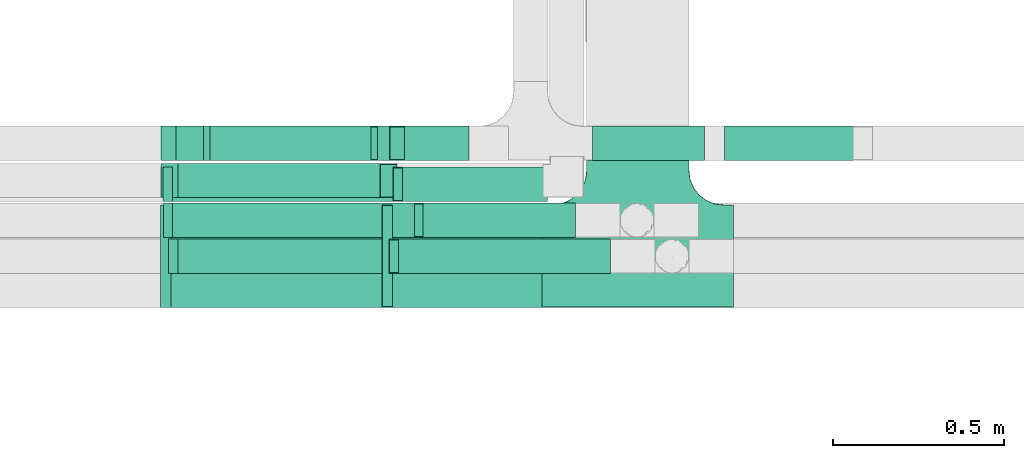
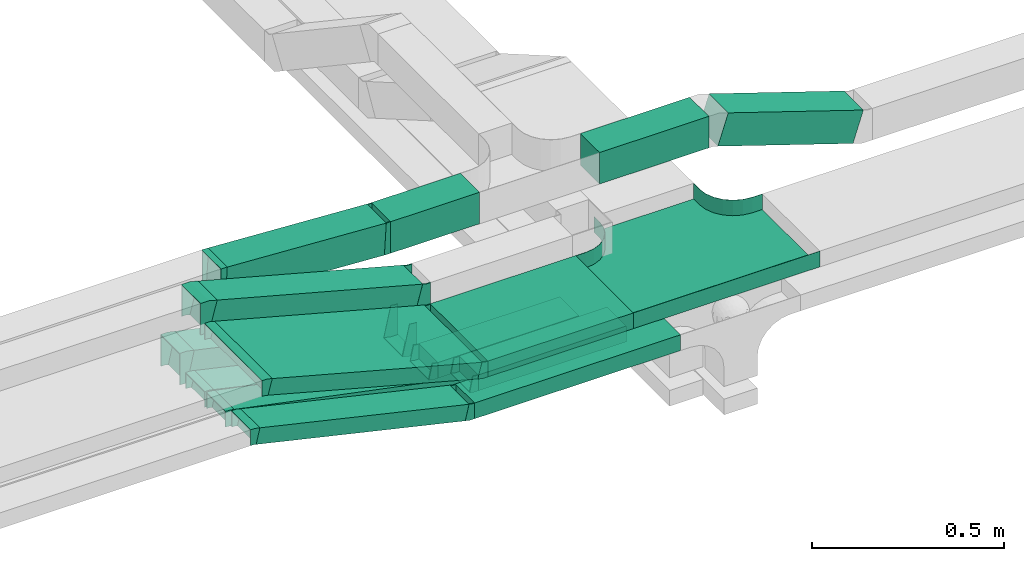
# One storey, part 10 of 14: 15 flow fittings, 14 flow segments.
"""IFC2X3 building model written with IfcOpenShell, lengths in millimetres."""

from ifc_helpers import new_model, entity, si_unit, converted_unit, derived_unit, direction, frame, frame_2d, origin, origin_2d_with_axis, place, context, subcontext, project, spatial, rectangle, extrude, faceted_brep, source, transform, mapped, material, type_object, type_shapes, element, save


model = new_model("IFC2X3")

# Units and contexts
model_context = context("Model", 3, precision=0.01, world=origin(), true_north=direction((6.12303176911189e-17, 1.0)))
body_context = subcontext(model_context, "Body", "Model", "MODEL_VIEW")
ifc_project = project(units=[si_unit("LENGTHUNIT", "METRE", prefix="MILLI"), si_unit("AREAUNIT", "SQUARE_METRE"), si_unit("VOLUMEUNIT", "CUBIC_METRE"), converted_unit("PLANEANGLEUNIT", "DEGREE", entity("IfcRatioMeasure", 0.0174532925199433), si_unit("PLANEANGLEUNIT", "RADIAN"), dimensions=[0, 0, 0, 0, 0, 0, 0]), si_unit("MASSUNIT", "GRAM", prefix="KILO"), derived_unit("MASSDENSITYUNIT", [(si_unit("MASSUNIT", "GRAM", prefix="KILO"), 1), (si_unit("LENGTHUNIT", "METRE"), -3)]), derived_unit("MOMENTOFINERTIAUNIT", [(si_unit("LENGTHUNIT", "METRE"), 4)]), si_unit("TIMEUNIT", "SECOND"), si_unit("FREQUENCYUNIT", "HERTZ"), si_unit("THERMODYNAMICTEMPERATUREUNIT", "DEGREE_CELSIUS"), derived_unit("THERMALTRANSMITTANCEUNIT", [(si_unit("MASSUNIT", "GRAM", prefix="KILO"), 1), (si_unit("THERMODYNAMICTEMPERATUREUNIT", "KELVIN"), -1), (si_unit("TIMEUNIT", "SECOND"), -3)]), derived_unit("VOLUMETRICFLOWRATEUNIT", [(si_unit("LENGTHUNIT", "METRE"), 3), (si_unit("TIMEUNIT", "SECOND"), -1)]), derived_unit("MASSFLOWRATEUNIT", [(si_unit("MASSUNIT", "GRAM", prefix="KILO"), 1), (si_unit("TIMEUNIT", "SECOND"), -1)]), derived_unit("ROTATIONALFREQUENCYUNIT", [(si_unit("TIMEUNIT", "SECOND"), -1)]), si_unit("ELECTRICCURRENTUNIT", "AMPERE"), si_unit("ELECTRICVOLTAGEUNIT", "VOLT"), si_unit("POWERUNIT", "WATT"), si_unit("FORCEUNIT", "NEWTON", prefix="KILO"), si_unit("ILLUMINANCEUNIT", "LUX"), si_unit("LUMINOUSFLUXUNIT", "LUMEN"), si_unit("LUMINOUSINTENSITYUNIT", "CANDELA"), derived_unit("USERDEFINED", [(si_unit("MASSUNIT", "GRAM", prefix="KILO"), -1), (si_unit("LENGTHUNIT", "METRE"), -2), (si_unit("TIMEUNIT", "SECOND"), 3), (si_unit("LUMINOUSFLUXUNIT", "LUMEN"), 1)]), derived_unit("LINEARVELOCITYUNIT", [(si_unit("LENGTHUNIT", "METRE"), 1), (si_unit("TIMEUNIT", "SECOND"), -1)]), si_unit("PRESSUREUNIT", "PASCAL"), derived_unit("USERDEFINED", [(si_unit("LENGTHUNIT", "METRE"), -2), (si_unit("MASSUNIT", "GRAM", prefix="KILO"), 1), (si_unit("TIMEUNIT", "SECOND"), -2)]), derived_unit("LINEARFORCEUNIT", [(si_unit("MASSUNIT", "GRAM", prefix="KILO"), 1), (si_unit("LENGTHUNIT", "METRE"), 1), (si_unit("TIMEUNIT", "SECOND"), -2), (si_unit("LENGTHUNIT", "METRE"), -1)]), derived_unit("PLANARFORCEUNIT", [(si_unit("MASSUNIT", "GRAM", prefix="KILO"), 1), (si_unit("LENGTHUNIT", "METRE"), 1), (si_unit("TIMEUNIT", "SECOND"), -2), (si_unit("LENGTHUNIT", "METRE"), -2)])], contexts=[model_context])

# Site, building, storey
site_placement = place(None, origin())
site = spatial("IfcSite", under=ifc_project, at=site_placement, CompositionType="ELEMENT")
building_placement = place(site_placement, origin())
building = spatial("IfcBuilding", under=site, at=building_placement, CompositionType="ELEMENT")
storey_placement = place(building_placement, frame((0.0, 0.0, 19800.0)))
storey = spatial("IfcBuildingStorey", under=building, at=storey_placement, CompositionType="ELEMENT", Elevation=19800.0)

# Flow segments
cable_carrier_segment_type = type_object("IfcCableCarrierSegmentType", PredefinedType="CABLETRAYSEGMENT")
flow_segment_1_placement = place(storey_placement, frame((63916.07, 9720.0, 2800.0)))
element("IfcFlowSegment", 1, at=flow_segment_1_placement, inside=storey, type_object=cable_carrier_segment_type, context=body_context, shape_type="SweptSolid", body=[
    extrude(rectangle(XDim=444.461560115162, YDim=99.9999999999989, at=origin_2d_with_axis()), frame((222.23, 50.0, 0.0), z_axis=(0.0, 0.0, 1.0), x_axis=(-1.0, 0.0, 0.0)), (0.0, 0.0, 1.0), 49.9999999999973),
])
flow_segment_2_placement = place(storey_placement, frame((63844.36, 9615.0, 2800.0)))
element("IfcFlowSegment", 2, at=flow_segment_2_placement, inside=storey, type_object=cable_carrier_segment_type, context=body_context, shape_type="SweptSolid", body=[
    extrude(rectangle(XDim=618.676195552314, YDim=100.000000000001, at=origin_2d_with_axis()), frame((309.34, 50.0, 0.0), z_axis=(0.0, 0.0, 1.0), x_axis=(-1.0, 0.0, 0.0)), (0.0, 0.0, 1.0), 49.9999999999973),
])
flow_segment_3_placement = place(storey_placement, frame((64765.17, 9945.0, 3009.28)))
element("IfcFlowSegment", 3, at=flow_segment_3_placement, inside=storey, type_object=cable_carrier_segment_type, context=body_context, shape_type="SweptSolid", body=[
    extrude(rectangle(XDim=99.9999999999972, YDim=99.9999999999989, at=origin_2d_with_axis()), frame((15.59, 50.0, 180.61), z_axis=(0.950175096611784, 0.0, -0.311716675490399), x_axis=(0.311716675490399, 0.0, 0.950175096611784)), (0.0, 0.0, 1.0), 426.997112921798),
])
flow_segment_4_placement = place(storey_placement, frame((64410.06, 9945.0, 3146.68)))
element("IfcFlowSegment", 4, at=flow_segment_4_placement, inside=storey, type_object=cable_carrier_segment_type, context=body_context, shape_type="SweptSolid", body=[
    extrude(rectangle(XDim=328.216762954596, YDim=99.9999999999989, at=origin_2d_with_axis()), frame((164.11, 50.0, 0.0)), (0.0, 0.0, 1.0), 100.000000000003),
])
flow_segment_5_placement = place(storey_placement, frame((63826.54, 9515.0, 3000.0)))
element("IfcFlowSegment", 5, at=flow_segment_5_placement, inside=storey, type_object=cable_carrier_segment_type, context=body_context, shape_type="SweptSolid", body=[
    extrude(rectangle(XDim=436.498088942979, YDim=300.000000000001, at=origin_2d_with_axis()), frame((218.25, 150.0, 0.0), z_axis=(0.0, 0.0, 1.0), x_axis=(-1.0, 0.0, 0.0)), (0.0, 0.0, 1.0), 49.9999999999973),
])
flow_segment_6_placement = place(storey_placement, frame((63173.53, 9836.0, 3006.58)))
element("IfcFlowSegment", 6, at=flow_segment_6_placement, inside=storey, type_object=cable_carrier_segment_type, context=body_context, shape_type="SweptSolid", body=[
    extrude(rectangle(XDim=99.999999999999, YDim=99.9999999999989, at=frame_2d((0.0, 0.0), x_axis=(0.0, 1.0))), frame((12.94, 50.0, 213.55), z_axis=(0.965925826289069, 0.0, -0.258819045102519), x_axis=(0.0, 1.0, 0.0)), (0.0, 0.0, 1.0), 638.501182800934),
])
flow_segment_7_placement = place(storey_placement, frame((63166.54, 9515.0, 3004.02)))
element("IfcFlowSegment", 7, at=flow_segment_7_placement, inside=storey, type_object=cable_carrier_segment_type, context=body_context, shape_type="SweptSolid", body=[
    extrude(rectangle(XDim=49.9999999999985, YDim=299.999999999999, at=origin_2d_with_axis()), frame((6.47, 150.0, 192.81), z_axis=(0.96592582628904, 4.1991581397727e-08, -0.258819045102621), x_axis=(0.258819045102621, 1.19570188417132e-08, 0.965925826289041)), (0.0, 0.0, 1.0), 651.666301653679),
])
flow_segment_8_placement = place(storey_placement, frame((63855.59, 9825.0, 2797.27)))
element("IfcFlowSegment", 8, at=flow_segment_8_placement, inside=storey, type_object=cable_carrier_segment_type, context=body_context, shape_type="SweptSolid", body=[
    extrude(rectangle(XDim=423.413526170801, YDim=99.9999999999989, at=origin_2d_with_axis()), frame((211.71, 50.0, 0.0)), (0.0, 0.0, 1.0), 49.9999999999973),
])
flow_segment_9_placement = place(storey_placement, frame((63171.78, 9945.0, 2804.73)))
element("IfcFlowSegment", 9, at=flow_segment_9_placement, inside=storey, type_object=cable_carrier_segment_type, context=body_context, shape_type="SweptSolid", body=[
    extrude(rectangle(XDim=100.000000000001, YDim=99.9999999999989, at=origin_2d_with_axis()), frame((10.79, 50.0, 191.71), z_axis=(0.976432143455112, 0.0, -0.215824626091779), x_axis=(0.215824626091779, 0.0, 0.976432143455112)), (0.0, 0.0, 1.0), 662.076920748981),
])
flow_segment_10_placement = place(storey_placement, frame((63172.09, 9825.0, 2800.33)))
element("IfcFlowSegment", 10, at=flow_segment_10_placement, inside=storey, type_object=cable_carrier_segment_type, context=body_context, shape_type="SweptSolid", body=[
    extrude(rectangle(XDim=49.9999999999987, YDim=99.9999999999989, at=origin_2d_with_axis()), frame((5.5, 50.0, 172.23), z_axis=(0.975535107739087, 0.0, -0.219843702590016), x_axis=(0.219843702590016, 0.0, 0.975535107739087)), (0.0, 0.0, 1.0), 672.484845813167),
])
flow_segment_11_placement = place(storey_placement, frame((63173.63, 9720.0, 2802.6)))
element("IfcFlowSegment", 11, at=flow_segment_11_placement, inside=storey, type_object=cable_carrier_segment_type, context=body_context, shape_type="SweptSolid", body=[
    extrude(rectangle(XDim=50.0000000000011, YDim=100.0, at=origin_2d_with_axis()), frame((4.98, 50.0, 170.3), z_axis=(0.979923045991076, 0.0, -0.199376086669318), x_axis=(0.199376086669318, 0.0, 0.979923045991076)), (0.0, 0.0, 1.0), 731.270116832418),
])
flow_segment_12_placement = place(storey_placement, frame((63188.73, 9615.0, 2803.18)))
element("IfcFlowSegment", 12, at=flow_segment_12_placement, inside=storey, type_object=cable_carrier_segment_type, context=body_context, shape_type="SweptSolid", body=[
    extrude(rectangle(XDim=49.9999999999962, YDim=99.9999999999989, at=origin_2d_with_axis()), frame((5.62, 50.0, 169.29), z_axis=(0.974370064785255, 0.0, -0.224951054343782), x_axis=(0.224951054343782, 0.0, 0.974370064785255)), (0.0, 0.0, 1.0), 644.278805474705),
])
flow_segment_13_placement = place(storey_placement, frame((63783.07, 9945.0, 3146.68)))
element("IfcFlowSegment", 13, at=flow_segment_13_placement, inside=storey, type_object=cable_carrier_segment_type, context=body_context, shape_type="SweptSolid", body=[
    extrude(rectangle(XDim=266.988683525038, YDim=99.9999999999989, at=origin_2d_with_axis()), frame((133.49, 50.0, 0.0), z_axis=(0.0, 0.0, 1.0), x_axis=(-1.0, 0.0, 0.0)), (0.0, 0.0, 1.0), 100.000000000003),
])
flow_segment_14_placement = place(storey_placement, frame((63286.9, 9945.0, 3147.22)))
element("IfcFlowSegment", 14, at=flow_segment_14_placement, inside=storey, type_object=cable_carrier_segment_type, context=body_context, shape_type="SweptSolid", body=[
    extrude(rectangle(XDim=100.000000000003, YDim=99.9999999999989, at=frame_2d((0.0, 0.0), x_axis=(0.0, 1.0))), frame((2.87, 50.0, 77.32), z_axis=(0.998356358345245, 0.0, -0.0573112707206922), x_axis=(0.0, 1.0, 0.0)), (0.0, 0.0, 1.0), 478.077091125566),
])

# Flow fittings
ifc_material = material()
cable_carrier_fitting_type_1 = type_object("IfcCableCarrierFittingType", PredefinedType="NOTDEFINED", material=ifc_material)
shared_shape_1 = source(origin(), body_context, "Body", "Brep", [
    faceted_brep([(-153.41, -224.12, 25.0), (-150.0, -250.0, 25.0), (-150.0, -280.0, 25.0), (-149.2, -280.0, 25.0), (-149.2, -250.0, 25.0), (-152.63, -223.91, 25.0), (-162.7, -199.6, 25.0), (-178.72, -178.72, 25.0), (-199.6, -162.7, 25.0), (-223.91, -152.63, 25.0), (-250.0, -149.2, 25.0), (-280.0, -149.2, 25.0), (-280.0, -150.0, 25.0), (-250.0, -150.0, 25.0), (-224.12, -153.41, 25.0), (-200.0, -163.4, 25.0), (-179.29, -179.29, 25.0), (-163.4, -200.0, 25.0), (280.0, -150.0, 25.0), (280.0, -149.2, 25.0), (250.0, -149.2, 25.0), (223.91, -152.63, 25.0), (199.6, -162.7, 25.0), (178.72, -178.72, 25.0), (162.7, -199.6, 25.0), (152.63, -223.91, 25.0), (149.2, -250.0, 25.0), (149.2, -280.0, 25.0), (150.0, -280.0, 25.0), (150.0, -250.0, 25.0), (153.41, -224.12, 25.0), (163.4, -200.0, 25.0), (179.29, -179.29, 25.0), (200.0, -163.4, 25.0), (224.12, -153.41, 25.0), (250.0, -150.0, 25.0), (280.0, 149.2, 25.0), (280.0, 150.0, 25.0), (-280.0, 150.0, 25.0), (-280.0, 149.2, 25.0), (-280.0, -150.0, -25.0), (-280.0, 150.0, -25.0), (280.0, 150.0, -25.0), (280.0, -150.0, -25.0), (250.0, -150.0, -25.0), (224.12, -153.41, -25.0), (200.0, -163.4, -25.0), (179.29, -179.29, -25.0), (163.4, -200.0, -25.0), (153.41, -224.12, -25.0), (150.0, -250.0, -25.0), (150.0, -280.0, -25.0), (-150.0, -280.0, -25.0), (-150.0, -250.0, -25.0), (-153.41, -224.12, -25.0), (-163.4, -200.0, -25.0), (-179.29, -179.29, -25.0), (-200.0, -163.4, -25.0), (-224.12, -153.41, -25.0), (-250.0, -150.0, -25.0), (-150.0, -250.0, -24.2), (149.2, -280.0, -24.2), (-149.2, -280.0, -24.2), (-149.2, -250.0, -24.2), (-250.0, -149.2, -24.2), (-280.0, -149.2, -24.2), (280.0, -149.2, -24.2), (250.0, -149.2, -24.2), (-280.0, 149.2, -24.2), (-250.0, -150.0, -24.2), (250.0, -150.0, -24.2), (280.0, 149.2, -24.2), (149.2, -250.0, -24.2), (150.0, -250.0, -24.2), (-223.91, -152.63, -24.2), (-199.6, -162.7, -24.2), (-178.72, -178.72, -24.2), (-162.7, -199.6, -24.2), (-152.63, -223.91, -24.2), (152.63, -223.91, -24.2), (162.7, -199.6, -24.2), (178.72, -178.72, -24.2), (199.6, -162.7, -24.2), (223.91, -152.63, -24.2)], [[[0, 1, 2, 3, 4, 5, 6, 7, 8, 9, 10, 11, 12, 13, 14, 15, 16, 17]], [[18, 19, 20, 21, 22, 23, 24, 25, 26, 27, 28, 29, 30, 31, 32, 33, 34, 35]], [[36, 37, 38, 39]], [[40, 41, 42, 43, 44, 45, 46, 47, 48, 49, 50, 51, 52, 53, 54, 55, 56, 57, 58, 59]], [[2, 1, 60, 53, 52]], [[3, 2, 52, 51, 28, 27, 61, 62]], [[4, 3, 62, 63]], [[11, 10, 64, 65]], [[20, 19, 66, 67]], [[39, 38, 41, 40, 12, 11, 65, 68]], [[13, 12, 40, 59, 69]], [[18, 35, 70, 44, 43]], [[19, 18, 43, 42, 37, 36, 71, 66]], [[27, 26, 72, 61]], [[29, 28, 51, 50, 73]], [[38, 37, 42, 41]], [[36, 39, 68, 71]], [[68, 65, 64, 74, 75, 76, 77, 78, 63, 62, 61, 72, 79, 80, 81, 82, 83, 67, 66, 71]], [[14, 13, 69, 59, 58]], [[58, 57, 15, 14]], [[15, 57, 56, 16]], [[0, 17, 55, 54]], [[0, 54, 53, 60, 1]], [[55, 17, 16, 56]], [[5, 4, 63, 78]], [[6, 5, 78, 77]], [[7, 6, 77, 76]], [[8, 7, 76, 75]], [[9, 8, 75, 74]], [[10, 9, 74, 64]], [[21, 20, 67, 83]], [[22, 21, 83, 82]], [[23, 22, 82, 81]], [[81, 80, 24, 23]], [[24, 80, 79, 25]], [[79, 72, 26, 25]], [[30, 29, 73, 50, 49]], [[31, 30, 49, 48]], [[31, 48, 47, 32]], [[33, 32, 47, 46]], [[45, 34, 33, 46]], [[34, 45, 44, 70, 35]]]),
])
type_shapes(cable_carrier_fitting_type_1, [shared_shape_1])
flow_fitting_placement = place(storey_placement, frame((64543.04, 9665.0, 3025.0), z_axis=(0.0, 0.0, 1.0), x_axis=(-1.0, 0.0, 0.0)))
element("IfcFlowFitting", 15, at=flow_fitting_placement, inside=storey, type_object=cable_carrier_fitting_type_1, material=ifc_material, Name="470_DKC_S5_T", context=body_context, shape_type="MappedRepresentation", body=[
    mapped(shared_shape_1, transform((0.0, 0.0, 0.0), scale=1.0)),
])
cable_carrier_fitting_type_2 = type_object("IfcCableCarrierFittingType", PredefinedType="NOTDEFINED", material=ifc_material)
shared_shape_2 = source(origin(), body_context, "Body", "Brep", [
    faceted_brep([(-12.24, -25.0, 150.0), (-12.24, 25.0, 150.0), (-12.24, 25.0, 147.46), (-12.24, -22.46, 147.46), (-12.24, -22.46, -147.46), (-12.24, 25.0, -147.46), (-12.24, 25.0, -150.0), (-12.24, -25.0, -150.0), (18.29, -20.98, 150.0), (18.29, -20.98, -150.0), (5.35, 27.32, -150.0), (5.35, 27.32, -147.46), (17.64, -18.53, -147.46), (17.64, -18.53, 147.46), (5.35, 27.32, 147.46), (5.35, 27.32, 150.0), (3.29, -25.0, 150.0), (-3.29, 25.0, 150.0), (-3.29, 25.0, 147.46), (2.96, -22.46, 147.46), (2.96, -22.46, -147.46), (-3.29, 25.0, -147.46), (-3.29, 25.0, -150.0), (3.29, -25.0, -150.0)], [[[0, 1, 2, 3, 4, 5, 6, 7]], [[8, 9, 10, 11, 12, 13, 14, 15]], [[1, 0, 16, 8, 15, 17]], [[2, 1, 17, 18]], [[3, 2, 18, 14, 13, 19]], [[4, 3, 19, 20]], [[5, 4, 20, 12, 11, 21]], [[6, 5, 21, 22]], [[7, 6, 22, 10, 9, 23]], [[0, 7, 23, 16]], [[18, 17, 15, 14]], [[20, 19, 13, 12]], [[22, 21, 11, 10]], [[16, 23, 9, 8]]]),
])
type_shapes(cable_carrier_fitting_type_2, [shared_shape_2])
for number, where, z_axis, x_axis in (
    (16, (63814.3, 9665.0, 3025.0), (0.0, 1.0, 1.62242993821036e-07), (-1.0, 0.0, 0.0)),
    (17, (63161.19, 9665.0, 3200.0), (0.0, -1.0, -1.62242998689715e-07), (-0.965925826289063, -4.19915779954446e-08, 0.258819045102537)),
):
    element("IfcFlowFitting", number, at=place(storey_placement, frame(where, z_axis=z_axis, x_axis=x_axis)), inside=storey, type_object=cable_carrier_fitting_type_2, material=ifc_material, context=body_context, shape_type="MappedRepresentation", body=[
        mapped(shared_shape_2, transform((0.0, 0.0, 0.0), scale=1.0)),
    ])
cable_carrier_fitting_type_3 = type_object("IfcCableCarrierFittingType", PredefinedType="NOTDEFINED", material=ifc_material)
shared_shape_3 = source(origin(), body_context, "Body", "Brep", [
    faceted_brep([(-8.01, -50.0, 50.0), (-8.01, 50.0, 50.0), (-8.01, 50.0, 47.46), (-8.01, -47.46, 47.46), (-8.01, -47.46, -47.46), (-8.01, 50.0, -47.46), (-8.01, 50.0, -50.0), (-8.01, -50.0, -50.0), (10.86, -49.46, 50.0), (10.86, -49.46, -50.0), (5.13, 50.38, -50.0), (5.13, 50.38, -47.46), (10.72, -46.92, -47.46), (10.72, -46.92, 47.46), (5.13, 50.38, 47.46), (5.13, 50.38, 50.0), (1.43, -50.0, 50.0), (-1.43, 50.0, 50.0), (-1.43, 50.0, 47.46), (1.36, -47.46, 47.46), (1.36, -47.46, -47.46), (-1.43, 50.0, -47.46), (-1.43, 50.0, -50.0), (1.43, -50.0, -50.0)], [[[0, 1, 2, 3, 4, 5, 6, 7]], [[8, 9, 10, 11, 12, 13, 14, 15]], [[1, 0, 16, 8, 15, 17]], [[2, 1, 17, 18]], [[3, 2, 18, 14, 13, 19]], [[4, 3, 19, 20]], [[5, 4, 20, 12, 11, 21]], [[6, 5, 21, 22]], [[7, 6, 22, 10, 9, 23]], [[0, 7, 23, 16]], [[18, 17, 15, 14]], [[20, 19, 13, 12]], [[22, 21, 11, 10]], [[16, 23, 9, 8]]]),
])
type_shapes(cable_carrier_fitting_type_3, [shared_shape_3])
for number, where, z_axis, x_axis in (
    (18, (63281.77, 9995.0, 3225.0), (0.0, 1.0, 0.0), (1.0, 0.0, 0.0)),
    (19, (63775.06, 9995.0, 3196.68), (0.0, 1.0, 0.0), (-1.0, 0.0, 0.0)),
):
    element("IfcFlowFitting", number, at=place(storey_placement, frame(where, z_axis=z_axis, x_axis=x_axis)), inside=storey, type_object=cable_carrier_fitting_type_3, material=ifc_material, context=body_context, shape_type="MappedRepresentation", body=[
        mapped(shared_shape_3, transform((0.0, 0.0, 0.0), scale=1.0)),
    ])
cable_carrier_fitting_type_4 = type_object("IfcCableCarrierFittingType", PredefinedType="NOTDEFINED", material=ifc_material)
shared_shape_4 = source(origin(), body_context, "Body", "Brep", [
    faceted_brep([(-18.82, -50.0, 50.0), (-18.82, 50.0, 50.0), (-18.82, 50.0, 47.46), (-18.82, -47.46, 47.46), (-18.82, -47.46, -47.46), (-18.82, 50.0, -47.46), (-18.82, 50.0, -50.0), (-18.82, -50.0, -50.0), (31.12, -43.42, 50.0), (31.12, -43.42, -50.0), (5.24, 53.17, -50.0), (5.24, 53.17, -47.46), (30.47, -40.97, -47.46), (30.47, -40.97, 47.46), (5.24, 53.17, 47.46), (5.24, 53.17, 50.0), (6.58, -50.0, 50.0), (-6.58, 50.0, 50.0), (-6.58, 50.0, 47.46), (6.25, -47.46, 47.46), (6.25, -47.46, -47.46), (-6.58, 50.0, -47.46), (-6.58, 50.0, -50.0), (6.58, -50.0, -50.0)], [[[0, 1, 2, 3, 4, 5, 6, 7]], [[8, 9, 10, 11, 12, 13, 14, 15]], [[1, 0, 16, 8, 15, 17]], [[2, 1, 17, 18]], [[3, 2, 18, 14, 13, 19]], [[4, 3, 19, 20]], [[5, 4, 20, 12, 11, 21]], [[6, 5, 21, 22]], [[7, 6, 22, 10, 9, 23]], [[0, 7, 23, 16]], [[18, 17, 15, 14]], [[20, 19, 13, 12]], [[22, 21, 11, 10]], [[16, 23, 9, 8]]]),
])
type_shapes(cable_carrier_fitting_type_4, [shared_shape_4])
for number, where, z_axis, x_axis in (
    (20, (63168.29, 9886.0, 3225.0), (0.0, 1.0, 0.0), (1.0, 0.0, 0.0)),
    (21, (63821.39, 9886.0, 3050.0), (2.08688699966324e-08, -1.0, 7.78836831239711e-08), (0.965925826289059, 0.0, -0.258819045102554)),
):
    element("IfcFlowFitting", number, at=place(storey_placement, frame(where, z_axis=z_axis, x_axis=x_axis)), inside=storey, type_object=cable_carrier_fitting_type_4, material=ifc_material, context=body_context, shape_type="MappedRepresentation", body=[
        mapped(shared_shape_4, transform((0.0, 0.0, 0.0), scale=1.0)),
    ])
cable_carrier_fitting_type_5 = type_object("IfcCableCarrierFittingType", PredefinedType="NOTDEFINED", material=ifc_material)
shared_shape_5 = source(origin(), body_context, "Body", "Brep", [
    faceted_brep([(-11.27, -25.0, 50.0), (-11.27, 25.0, 50.0), (-11.27, 25.0, 47.46), (-11.27, -22.46, 47.46), (-11.27, -22.46, -47.46), (-11.27, 25.0, -47.46), (-11.27, 25.0, -50.0), (-11.27, -25.0, -50.0), (16.6, -21.82, 50.0), (16.6, -21.82, -50.0), (5.35, 26.89, -50.0), (5.35, 26.89, -47.46), (16.03, -19.35, -47.46), (16.03, -19.35, 47.46), (5.35, 26.89, 47.46), (5.35, 26.89, 50.0), (2.85, -25.0, 50.0), (-2.85, 25.0, 50.0), (-2.85, 25.0, 47.46), (2.56, -22.46, 47.46), (2.56, -22.46, -47.46), (-2.85, 25.0, -47.46), (-2.85, 25.0, -50.0), (2.85, -25.0, -50.0)], [[[0, 1, 2, 3, 4, 5, 6, 7]], [[8, 9, 10, 11, 12, 13, 14, 15]], [[1, 0, 16, 8, 15, 17]], [[2, 1, 17, 18]], [[3, 2, 18, 14, 13, 19]], [[4, 3, 19, 20]], [[5, 4, 20, 12, 11, 21]], [[6, 5, 21, 22]], [[7, 6, 22, 10, 9, 23]], [[0, 7, 23, 16]], [[18, 17, 15, 14]], [[20, 19, 13, 12]], [[22, 21, 11, 10]], [[16, 23, 9, 8]]]),
])
type_shapes(cable_carrier_fitting_type_5, [shared_shape_5])
for number, where, z_axis, x_axis in (
    (22, (63833.1, 9665.0, 2825.0), (0.0, 1.0, 0.0), (-1.0, 0.0, 0.0)),
    (23, (63183.37, 9665.0, 2975.0), (0.0, -1.0, 0.0), (-0.974370064785237, 0.0, 0.22495105434386)),
):
    element("IfcFlowFitting", number, at=place(storey_placement, frame(where, z_axis=z_axis, x_axis=x_axis)), inside=storey, type_object=cable_carrier_fitting_type_5, material=ifc_material, context=body_context, shape_type="MappedRepresentation", body=[
        mapped(shared_shape_5, transform((0.0, 0.0, 0.0), scale=1.0)),
    ])
cable_carrier_fitting_type_6 = type_object("IfcCableCarrierFittingType", PredefinedType="NOTDEFINED", material=ifc_material)
shared_shape_6 = source(origin(), body_context, "Body", "Brep", [
    faceted_brep([(-10.54, -25.0, 50.0), (-10.54, 25.0, 50.0), (-10.54, 25.0, 47.46), (-10.54, -22.46, 47.46), (-10.54, -22.46, -47.46), (-10.54, 25.0, -47.46), (-10.54, 25.0, -50.0), (-10.54, -25.0, -50.0), (15.31, -22.4, 50.0), (15.31, -22.4, -50.0), (5.34, 26.6, -50.0), (5.34, 26.6, -47.46), (14.8, -19.91, -47.46), (14.8, -19.91, 47.46), (5.34, 26.6, 47.46), (5.34, 26.6, 50.0), (2.52, -25.0, 50.0), (-2.52, 25.0, 50.0), (-2.52, 25.0, 47.46), (2.26, -22.46, 47.46), (2.26, -22.46, -47.46), (-2.52, 25.0, -47.46), (-2.52, 25.0, -50.0), (2.52, -25.0, -50.0)], [[[0, 1, 2, 3, 4, 5, 6, 7]], [[8, 9, 10, 11, 12, 13, 14, 15]], [[1, 0, 16, 8, 15, 17]], [[2, 1, 17, 18]], [[3, 2, 18, 14, 13, 19]], [[4, 3, 19, 20]], [[5, 4, 20, 12, 11, 21]], [[6, 5, 21, 22]], [[7, 6, 22, 10, 9, 23]], [[0, 7, 23, 16]], [[18, 17, 15, 14]], [[20, 19, 13, 12]], [[22, 21, 11, 10]], [[16, 23, 9, 8]]]),
])
type_shapes(cable_carrier_fitting_type_6, [shared_shape_6])
for number, where, z_axis, x_axis in (
    (24, (63905.53, 9770.0, 2825.0), (0.0, 1.0, 0.0), (-1.0, 0.0, 0.0)),
    (25, (63168.29, 9770.0, 2975.0), (0.0, -1.0, 0.0), (-0.979923045991058, 0.0, 0.199376086669409)),
):
    element("IfcFlowFitting", number, at=place(storey_placement, frame(where, z_axis=z_axis, x_axis=x_axis)), inside=storey, type_object=cable_carrier_fitting_type_6, material=ifc_material, context=body_context, shape_type="MappedRepresentation", body=[
        mapped(shared_shape_6, transform((0.0, 0.0, 0.0), scale=1.0)),
    ])
cable_carrier_fitting_type_7 = type_object("IfcCableCarrierFittingType", PredefinedType="NOTDEFINED", material=ifc_material)
shared_shape_7 = source(origin(), body_context, "Body", "Brep", [
    faceted_brep([(-11.12, -25.0, 50.0), (-11.12, 25.0, 50.0), (-11.12, 25.0, 47.46), (-11.12, -22.46, 47.46), (-11.12, -22.46, -47.46), (-11.12, 25.0, -47.46), (-11.12, 25.0, -50.0), (-11.12, -25.0, -50.0), (16.34, -21.94, 50.0), (16.34, -21.94, -50.0), (5.35, 26.83, -50.0), (5.35, 26.83, -47.46), (15.79, -19.47, -47.46), (15.79, -19.47, 47.46), (5.35, 26.83, 47.46), (5.35, 26.83, 50.0), (2.78, -25.0, 50.0), (-2.78, 25.0, 50.0), (-2.78, 25.0, 47.46), (2.5, -22.46, 47.46), (2.5, -22.46, -47.46), (-2.78, 25.0, -47.46), (-2.78, 25.0, -50.0), (2.78, -25.0, -50.0)], [[[0, 1, 2, 3, 4, 5, 6, 7]], [[8, 9, 10, 11, 12, 13, 14, 15]], [[1, 0, 16, 8, 15, 17]], [[2, 1, 17, 18]], [[3, 2, 18, 14, 13, 19]], [[4, 3, 19, 20]], [[5, 4, 20, 12, 11, 21]], [[6, 5, 21, 22]], [[7, 6, 22, 10, 9, 23]], [[0, 7, 23, 16]], [[18, 17, 15, 14]], [[20, 19, 13, 12]], [[22, 21, 11, 10]], [[16, 23, 9, 8]]]),
])
type_shapes(cable_carrier_fitting_type_7, [shared_shape_7])
for number, where, z_axis, x_axis in (
    (26, (63844.47, 9875.0, 2822.27), (0.0, 1.0, 0.0), (-1.0, 0.0, 0.0)),
    (27, (63166.74, 9875.0, 2975.0), (0.0, -1.0, 0.0), (-0.975535107739096, 0.0, 0.219843702589976)),
):
    element("IfcFlowFitting", number, at=place(storey_placement, frame(where, z_axis=z_axis, x_axis=x_axis)), inside=storey, type_object=cable_carrier_fitting_type_7, material=ifc_material, context=body_context, shape_type="MappedRepresentation", body=[
        mapped(shared_shape_7, transform((0.0, 0.0, 0.0), scale=1.0)),
    ])
cable_carrier_fitting_type_8 = type_object("IfcCableCarrierFittingType", PredefinedType="NOTDEFINED", material=ifc_material)
shared_shape_8 = source(origin(), body_context, "Body", "Brep", [
    faceted_brep([(-16.47, -50.0, 50.0), (-16.47, 50.0, 50.0), (-16.47, 50.0, 47.46), (-16.47, -47.46, 47.46), (-16.47, -47.46, -47.46), (-16.47, 50.0, -47.46), (-16.47, 50.0, -50.0), (-16.47, -50.0, -50.0), (26.87, -45.27, 50.0), (26.87, -45.27, -50.0), (5.29, 52.38, -50.0), (5.29, 52.38, -47.46), (26.32, -42.79, -47.46), (26.32, -42.79, 47.46), (5.29, 52.38, 47.46), (5.29, 52.38, 50.0), (5.46, -50.0, 50.0), (-5.46, 50.0, 50.0), (-5.46, 50.0, 47.46), (5.18, -47.46, 47.46), (5.18, -47.46, -47.46), (-5.46, 50.0, -47.46), (-5.46, 50.0, -50.0), (5.46, -50.0, -50.0)], [[[0, 1, 2, 3, 4, 5, 6, 7]], [[8, 9, 10, 11, 12, 13, 14, 15]], [[1, 0, 16, 8, 15, 17]], [[2, 1, 17, 18]], [[3, 2, 18, 14, 13, 19]], [[4, 3, 19, 20]], [[5, 4, 20, 12, 11, 21]], [[6, 5, 21, 22]], [[7, 6, 22, 10, 9, 23]], [[0, 7, 23, 16]], [[18, 17, 15, 14]], [[20, 19, 13, 12]], [[22, 21, 11, 10]], [[16, 23, 9, 8]]]),
])
type_shapes(cable_carrier_fitting_type_8, [shared_shape_8])
for number, where, z_axis, x_axis in (
    (28, (63845.12, 9995.0, 2850.0), (0.0, 1.0, 0.0), (-1.0, 0.0, 0.0)),
    (29, (63166.49, 9995.0, 3000.0), (0.0, 1.0, 0.0), (1.0, 0.0, 0.0)),
):
    element("IfcFlowFitting", number, at=place(storey_placement, frame(where, z_axis=z_axis, x_axis=x_axis)), inside=storey, type_object=cable_carrier_fitting_type_8, material=ifc_material, context=body_context, shape_type="MappedRepresentation", body=[
        mapped(shared_shape_8, transform((0.0, 0.0, 0.0), scale=1.0)),
    ])

save(model, "model.ifc")
